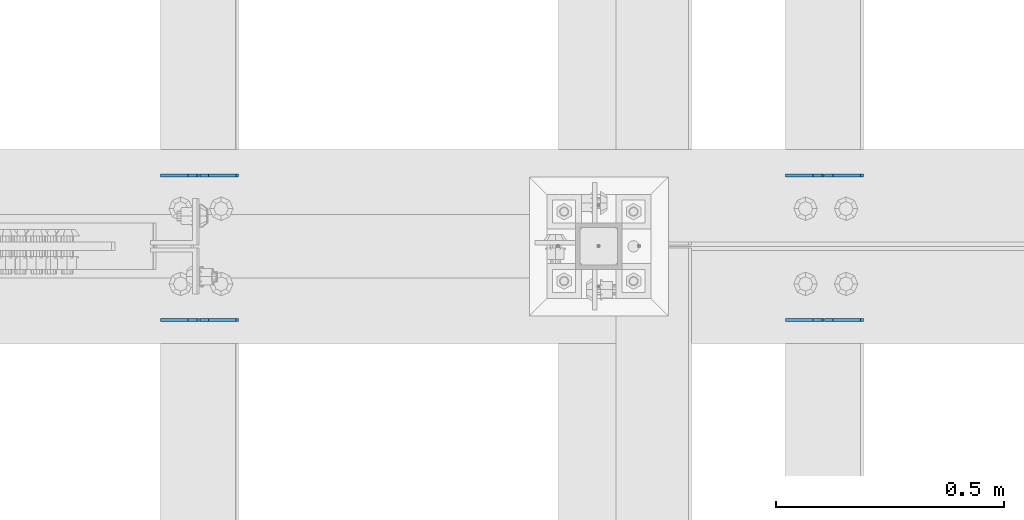
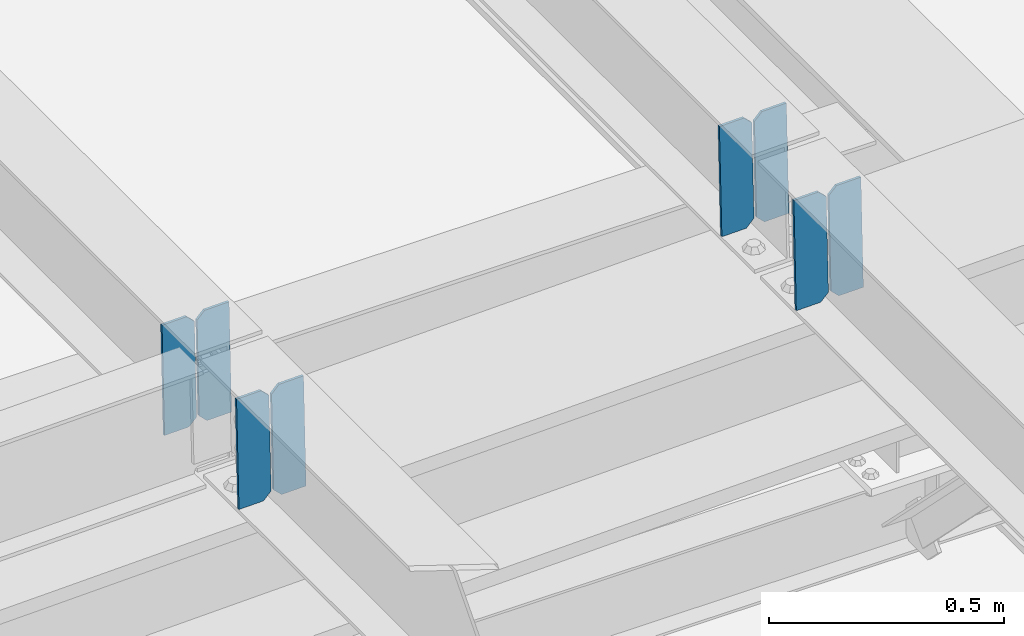
# One storey, part 3351 of 3843: 8 plates, 4 elements without a shape of their own.
"""IFC2X3 building model written with IfcOpenShell, lengths in millimetres."""

from ifc_helpers import new_model, si_unit, frame, origin_with_axes, place, context, subcontext, project, spatial, faceted_brep, material, type_object, element, aggregate, save


model = new_model("IFC2X3")

# Units and contexts
model_context = context("Model", 3, precision=1e-05, world=origin_with_axes())
body_context = subcontext(model_context, "Body", "Model", "MODEL_VIEW")
ifc_project = project(units=[si_unit("LENGTHUNIT", "METRE", prefix="MILLI"), si_unit("AREAUNIT", "SQUARE_METRE"), si_unit("VOLUMEUNIT", "CUBIC_METRE"), si_unit("MASSUNIT", "GRAM", prefix="KILO"), si_unit("TIMEUNIT", "SECOND"), si_unit("PLANEANGLEUNIT", "RADIAN"), si_unit("SOLIDANGLEUNIT", "STERADIAN"), si_unit("THERMODYNAMICTEMPERATUREUNIT", "DEGREE_CELSIUS"), si_unit("LUMINOUSINTENSITYUNIT", "LUMEN")], contexts=[model_context])

# Site, building, storey
site_placement = place(None, origin_with_axes())
site = spatial("IfcSite", under=ifc_project, at=site_placement, CompositionType="ELEMENT")
building_placement = place(site_placement, origin_with_axes())
building = spatial("IfcBuilding", under=site, at=building_placement, Name="Undefined", CompositionType="ELEMENT")
storey_placement = place(building_placement, origin_with_axes())
storey = spatial("IfcBuildingStorey", under=building, at=storey_placement, Name="Undefined", CompositionType="ELEMENT", Elevation=0.0)

# Assembly, plates
assembly_1_placement = place(storey_placement, origin_with_axes())
assembly_1 = element("IfcElementAssembly", 1, at=assembly_1_placement, inside=storey, Name="BEAM", AssemblyPlace="NOTDEFINED", PredefinedType="RIGID_FRAME")
ifc_material = material(Name="STEEL/A572-50")
plate_type = type_object("IfcPlateType", PredefinedType="NOTDEFINED")
plate_1_placement = place(assembly_1_placement, frame((38029.8964783233, 67427.4329969125, 45468.4121955251), z_axis=(-0.0211520982170187, 0.000140802000052645, 0.999776259427985), x_axis=(-0.999776269342228, -3.16699999781408e-06, -0.0211520980072162)))
plate_1 = element("IfcPlate", 2, at=plate_1_placement, type_object=plate_type, material=ifc_material, Name="PLATE", context=body_context, shape_type="Brep", body=[
    faceted_brep([(0.0, -3.17499999999927, 0.0), (6.83940015733242e-10, -3.17499999996653, 288.924999998613), (6.54836185276508e-10, 3.17500000001746, 288.924999998591), (0.0, 3.17499999999927, 0.0), (60.3250007643655, -3.17500000017753, 288.924999998606), (60.3250007643219, 3.17499999979918, 288.924999998584), (79.3750000013097, -3.17500000025029, 269.875000761494), (79.375000001266, 3.17499999972642, 269.875000761487), (79.375000000713, -3.17500000026484, 19.0499992370605), (79.3750000006985, 3.17499999971187, 19.0499992370533), (60.325000763667, -3.17500000020664, -1.45519152283669e-11), (60.3250007636234, 3.17499999977736, -3.63797880709171e-11)], [[[0, 1, 2, 3]], [[1, 4, 5, 2]], [[4, 6, 7, 5]], [[6, 8, 9, 7]], [[8, 10, 11, 9]], [[10, 0, 3, 11]], [[5, 7, 9, 11, 3, 2]], [[10, 8, 6, 4, 1, 0]]]),
])
plate_2_placement = place(assembly_1_placement, frame((37944.1906576337, 67427.4327415443, 45466.5989319415), z_axis=(-0.0211520982170187, 0.000140802000052645, 0.999776259427985), x_axis=(-0.999776269342228, -3.16699999781408e-06, -0.0211520980072162)))
plate_2 = element("IfcPlate", 3, at=plate_2_placement, type_object=plate_type, material=ifc_material, Name="PLATE", context=body_context, shape_type="Brep", body=[
    faceted_brep([(4.36557456851006e-11, -3.17499999998836, 19.0499992370969), (6.11180439591408e-10, -3.17499999996653, 269.875000761516), (5.96628524363041e-10, 3.17500000001746, 269.875000761502), (1.45519152283669e-11, 3.17499999998836, 19.0499992370824), (19.0499992376572, -3.17500000003201, 288.924999998606), (19.0499992376281, 3.1749999999447, 288.924999998584), (79.3750000013242, -3.17500000025029, 288.924999998591), (79.3750000013097, 3.1749999997337, 288.92499999857), (79.3750000006548, -3.17500000026484, -2.18278728425503e-11), (79.3750000006403, 3.17499999969732, -2.91038304567337e-11), (19.0499992370023, -3.17500000005384, 0.0), (19.0499992369587, 3.17499999992287, -1.45519152283669e-11)], [[[0, 1, 2, 3]], [[1, 4, 5, 2]], [[4, 6, 7, 5]], [[6, 8, 9, 7]], [[8, 10, 11, 9]], [[10, 0, 3, 11]], [[5, 7, 9, 11, 3, 2]], [[10, 8, 6, 4, 1, 0]]]),
])
aggregate(assembly_1, [plate_1, plate_2])

assembly_2_placement = place(storey_placement, origin_with_axes())
assembly_2 = element("IfcElementAssembly", 4, at=assembly_2_placement, inside=storey, Name="BEAM", AssemblyPlace="NOTDEFINED", PredefinedType="RIGID_FRAME")
plate_3_placement = place(assembly_2_placement, frame((38029.8964783288, 67109.969082567, 45468.4373096592), z_axis=(-0.021152098011531, 1.98379999928875e-05, 0.999776269150336), x_axis=(-0.999776270257024, 0.0, -0.0211520550054595)))
plate_3 = element("IfcPlate", 5, at=plate_3_placement, type_object=plate_type, material=ifc_material, Name="PLATE", context=body_context, shape_type="Brep", body=[
    faceted_brep([(0.0, -3.17499999999927, 0.0), (6.83940015733242e-10, -3.17499999996653, 288.924999998613), (6.54836185276508e-10, 3.17500000001746, 288.924999998591), (0.0, 3.17499999999927, 0.0), (60.3250007643655, -3.17500000017753, 288.924999998606), (60.3250007643219, 3.17499999979918, 288.924999998584), (79.3750000013097, -3.17500000025029, 269.875000761494), (79.375000001266, 3.17499999972642, 269.875000761487), (79.375000000713, -3.17500000026484, 19.0499992370605), (79.3750000006985, 3.17499999971187, 19.0499992370533), (60.325000763667, -3.17500000020664, -1.45519152283669e-11), (60.3250007636234, 3.17499999977736, -3.63797880709171e-11)], [[[0, 1, 2, 3]], [[1, 4, 5, 2]], [[4, 6, 7, 5]], [[6, 8, 9, 7]], [[8, 10, 11, 9]], [[10, 0, 3, 11]], [[5, 7, 9, 11, 3, 2]], [[10, 8, 6, 4, 1, 0]]]),
])
plate_4_placement = place(assembly_2_placement, frame((37944.1906576392, 67109.9690465864, 45466.6240460583), z_axis=(-0.021152098011531, 1.98379999928875e-05, 0.999776269150336), x_axis=(-0.999776270257024, 0.0, -0.0211520550054595)))
plate_4 = element("IfcPlate", 6, at=plate_4_placement, type_object=plate_type, material=ifc_material, Name="PLATE", context=body_context, shape_type="Brep", body=[
    faceted_brep([(4.36557456851006e-11, -3.17499999998836, 19.0499992370969), (6.11180439591408e-10, -3.17499999996653, 269.875000761516), (5.96628524363041e-10, 3.17500000001746, 269.875000761502), (1.45519152283669e-11, 3.17499999998836, 19.0499992370824), (19.0499992376572, -3.17500000003201, 288.924999998606), (19.0499992376281, 3.1749999999447, 288.924999998584), (79.3750000013242, -3.17500000025029, 288.924999998591), (79.3750000013097, 3.1749999997337, 288.92499999857), (79.3750000006548, -3.17500000026484, -2.18278728425503e-11), (79.3750000006403, 3.17499999969732, -2.91038304567337e-11), (19.0499992370023, -3.17500000005384, 0.0), (19.0499992369587, 3.17499999992287, -1.45519152283669e-11)], [[[0, 1, 2, 3]], [[1, 4, 5, 2]], [[4, 6, 7, 5]], [[6, 8, 9, 7]], [[8, 10, 11, 9]], [[10, 0, 3, 11]], [[5, 7, 9, 11, 3, 2]], [[10, 8, 6, 4, 1, 0]]]),
])
aggregate(assembly_2, [plate_3, plate_4])

assembly_3_placement = place(storey_placement, origin_with_axes())
assembly_3 = element("IfcElementAssembly", 7, at=assembly_3_placement, inside=storey, Name="BEAM", AssemblyPlace="NOTDEFINED", PredefinedType="RIGID_FRAME")
plate_5_placement = place(assembly_3_placement, frame((39401.4964783243, 67427.3922724117, 45505.2387115273), z_axis=(-0.0211520978211338, 0.00027729799997178, 0.999776230895486), x_axis=(-0.999776269348334, -6.33400000515396e-06, -0.0211520970073616)))
plate_5 = element("IfcPlate", 8, at=plate_5_placement, type_object=plate_type, material=ifc_material, Name="PLATE", context=body_context, shape_type="Brep", body=[
    faceted_brep([(0.0, -3.17499999999927, 0.0), (6.83940015733242e-10, -3.17499999996653, 288.924999998613), (6.54836185276508e-10, 3.17500000001746, 288.924999998591), (0.0, 3.17499999999927, 0.0), (60.3250007643655, -3.17500000017753, 288.924999998606), (60.3250007643219, 3.17499999979918, 288.924999998584), (79.3750000013097, -3.17500000025029, 269.875000761494), (79.375000001266, 3.17499999972642, 269.875000761487), (79.375000000713, -3.17500000026484, 19.0499992370605), (79.3750000006985, 3.17499999971187, 19.0499992370533), (60.325000763667, -3.17500000020664, -1.45519152283669e-11), (60.3250007636234, 3.17499999977736, -3.63797880709171e-11)], [[[0, 1, 2, 3]], [[1, 4, 5, 2]], [[4, 6, 7, 5]], [[6, 8, 9, 7]], [[8, 10, 11, 9]], [[10, 0, 3, 11]], [[5, 7, 9, 11, 3, 2]], [[10, 8, 6, 4, 1, 0]]]),
])
plate_6_placement = place(assembly_3_placement, frame((39315.7906576346, 67427.3917694846, 45503.4254479961), z_axis=(-0.0211520978211338, 0.00027729799997178, 0.999776230895486), x_axis=(-0.999776269348334, -6.33400000515396e-06, -0.0211520970073616)))
plate_6 = element("IfcPlate", 9, at=plate_6_placement, type_object=plate_type, material=ifc_material, Name="PLATE", context=body_context, shape_type="Brep", body=[
    faceted_brep([(4.36557456851006e-11, -3.17499999998836, 19.0499992370969), (6.11180439591408e-10, -3.17499999996653, 269.875000761516), (5.96628524363041e-10, 3.17500000001746, 269.875000761502), (1.45519152283669e-11, 3.17499999998836, 19.0499992370824), (19.0499992376572, -3.17500000003201, 288.924999998606), (19.0499992376281, 3.1749999999447, 288.924999998584), (79.3750000013242, -3.17500000025029, 288.924999998591), (79.3750000013097, 3.1749999997337, 288.92499999857), (79.3750000006548, -3.17500000026484, -2.18278728425503e-11), (79.3750000006403, 3.17499999969732, -2.91038304567337e-11), (19.0499992370023, -3.17500000005384, 0.0), (19.0499992369587, 3.17499999992287, -1.45519152283669e-11)], [[[0, 1, 2, 3]], [[1, 4, 5, 2]], [[4, 6, 7, 5]], [[6, 8, 9, 7]], [[8, 10, 11, 9]], [[10, 0, 3, 11]], [[5, 7, 9, 11, 3, 2]], [[10, 8, 6, 4, 1, 0]]]),
])
aggregate(assembly_3, [plate_5, plate_6])

assembly_4_placement = place(storey_placement, origin_with_axes())
assembly_4 = element("IfcElementAssembly", 10, at=assembly_4_placement, inside=storey, Name="BEAM", AssemblyPlace="NOTDEFINED", PredefinedType="RIGID_FRAME")
plate_7_placement = place(assembly_4_placement, frame((39401.496478327, 67110.1152590539, 45505.2057682409), z_axis=(-0.0211520983455921, -0.000470089999922493, 0.999776158823049), x_axis=(-0.999776269357268, 1.0337000006824e-05, -0.0211520950075907)))
plate_7 = element("IfcPlate", 11, at=plate_7_placement, type_object=plate_type, material=ifc_material, Name="PLATE", context=body_context, shape_type="Brep", body=[
    faceted_brep([(0.0, -3.17499999999927, 0.0), (6.83940015733242e-10, -3.17499999996653, 288.924999998613), (6.54836185276508e-10, 3.17500000001746, 288.924999998591), (0.0, 3.17499999999927, 0.0), (60.3250007643655, -3.17500000017753, 288.924999998606), (60.3250007643219, 3.17499999979918, 288.924999998584), (79.3750000013097, -3.17500000025029, 269.875000761494), (79.375000001266, 3.17499999972642, 269.875000761487), (79.375000000713, -3.17500000026484, 19.0499992370605), (79.3750000006985, 3.17499999971187, 19.0499992370533), (60.325000763667, -3.17500000020664, -1.45519152283669e-11), (60.3250007636234, 3.17499999977736, -3.63797880709171e-11)], [[[0, 1, 2, 3]], [[1, 4, 5, 2]], [[4, 6, 7, 5]], [[6, 8, 9, 7]], [[8, 10, 11, 9]], [[10, 0, 3, 11]], [[5, 7, 9, 11, 3, 2]], [[10, 8, 6, 4, 1, 0]]]),
])
plate_8_placement = place(assembly_4_placement, frame((39315.7906576373, 67110.1161116412, 45503.3925048404), z_axis=(-0.0211520983455921, -0.000470089999922493, 0.999776158823049), x_axis=(-0.999776269357268, 1.0337000006824e-05, -0.0211520950075907)))
plate_8 = element("IfcPlate", 12, at=plate_8_placement, type_object=plate_type, material=ifc_material, Name="PLATE", context=body_context, shape_type="Brep", body=[
    faceted_brep([(4.36557456851006e-11, -3.17499999998836, 19.0499992370969), (6.11180439591408e-10, -3.17499999996653, 269.875000761516), (5.96628524363041e-10, 3.17500000001746, 269.875000761502), (1.45519152283669e-11, 3.17499999998836, 19.0499992370824), (19.0499992376572, -3.17500000003201, 288.924999998606), (19.0499992376281, 3.1749999999447, 288.924999998584), (79.3750000013242, -3.17500000025029, 288.924999998591), (79.3750000013097, 3.1749999997337, 288.92499999857), (79.3750000006548, -3.17500000026484, -2.18278728425503e-11), (79.3750000006403, 3.17499999969732, -2.91038304567337e-11), (19.0499992370023, -3.17500000005384, 0.0), (19.0499992369587, 3.17499999992287, -1.45519152283669e-11)], [[[0, 1, 2, 3]], [[1, 4, 5, 2]], [[4, 6, 7, 5]], [[6, 8, 9, 7]], [[8, 10, 11, 9]], [[10, 0, 3, 11]], [[5, 7, 9, 11, 3, 2]], [[10, 8, 6, 4, 1, 0]]]),
])
aggregate(assembly_4, [plate_7, plate_8])

save(model, "model.ifc")
